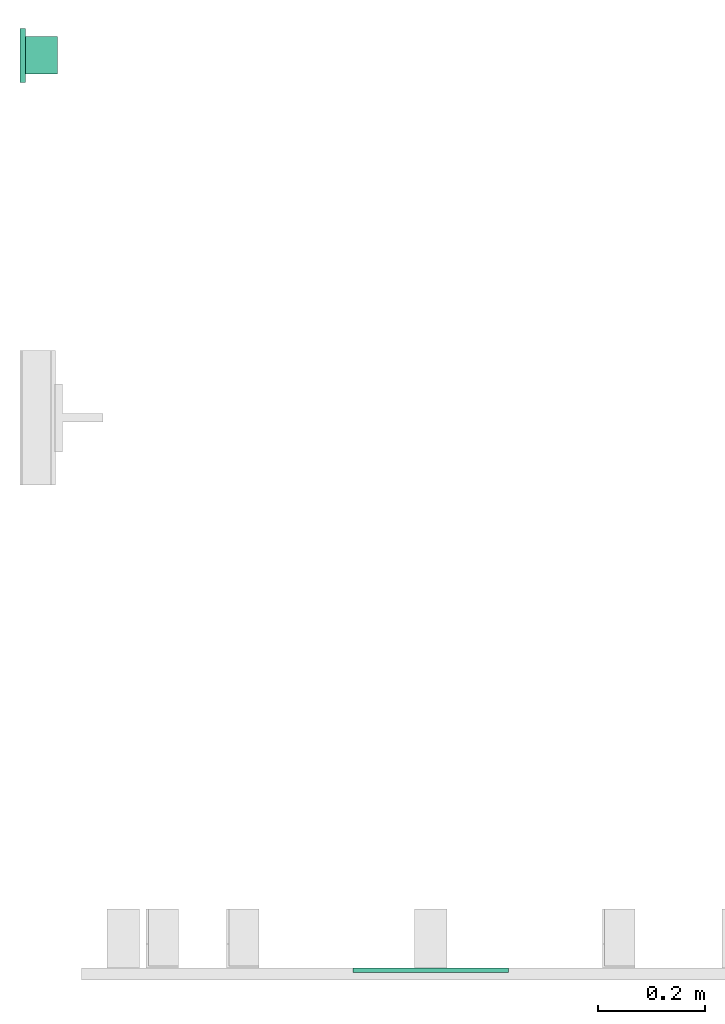
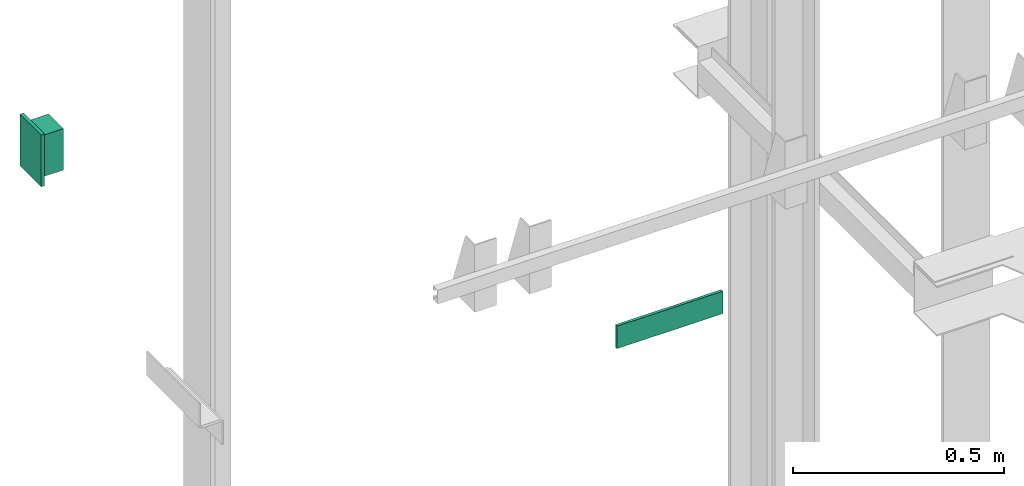
# One storey, part 2 of 3: 1 lamp, 1 switching device.
"""IFC4 building model written with IfcOpenShell, lengths in millimetres."""

from ifc_helpers import new_model, entity, si_unit, converted_unit, frame, origin_with_axes, place, context, subcontext, project, spatial, faceted_brep, element, save


model = new_model("IFC4")

# Units and contexts
context_of_model = context(None, 3, precision=0.01, world=origin_with_axes())
sub_context_1 = subcontext(context_of_model, None, None, "MODEL_VIEW")
sub_context_2 = subcontext(context_of_model, None, None, "MODEL_VIEW")
ifc_project = project(units=[converted_unit("PLANEANGLEUNIT", "degree", entity("IfcPlaneAngleMeasure", 0.017453292519943), si_unit("PLANEANGLEUNIT", "RADIAN"), dimensions=[0, 0, 0, 0, 0, 0, 0]), si_unit("LENGTHUNIT", "METRE", prefix="MILLI"), si_unit("MASSUNIT", "GRAM", prefix="KILO"), converted_unit("TIMEUNIT", "year", entity("IfcTimeMeasure", 31557600.0), si_unit("TIMEUNIT", "SECOND"), dimensions=[0, 0, 1, 0, 0, 0, 0]), si_unit("THERMODYNAMICTEMPERATUREUNIT", "DEGREE_CELSIUS"), si_unit("AREAUNIT", "SQUARE_METRE"), si_unit("FORCEUNIT", "NEWTON"), si_unit("VOLUMEUNIT", "CUBIC_METRE"), si_unit("PRESSUREUNIT", "PASCAL"), si_unit("SOLIDANGLEUNIT", "STERADIAN")], contexts=[context_of_model])

# Site, building, storey
site = spatial("IfcSite", under=ifc_project)
building = spatial("IfcBuilding", under=site, Name="Document")
placement = place(None, origin_with_axes())
storey_placement = place(placement, frame((0.0, 0.0, -4420.0), z_axis=(0.0, 0.0, 1.0), x_axis=(1.0, 0.0, 0.0)))
storey = spatial("IfcBuildingStorey", under=building, at=storey_placement, Name="-1", Elevation=-4420.0)

# Switching device
switching_device_placement = place(storey_placement, frame((765.0, 0.0, 2280.0), z_axis=(0.0, 0.0, 1.0), x_axis=(1.0, 0.0, 0.0)))
element("IfcSwitchingDevice", 1, at=switching_device_placement, inside=storey, context=sub_context_1, shape_type="Brep", body=[
    faceted_brep([(-145.0, -8.0, 32.5), (145.0, -8.0, 32.5), (145.0, 0.0, 32.5), (-145.0, 0.0, 32.5), (-145.0, -8.0, -32.5), (-145.0, 0.0, -32.5), (145.0, 0.0, -32.5), (145.0, -8.0, -32.5)], [[[0, 1, 2, 3]], [[4, 5, 6, 7]], [[0, 3, 5, 4]], [[3, 2, 6, 5]], [[2, 1, 7, 6]], [[1, 0, 4, 7]]]),
])

# Lamp
lamp_placement = place(storey_placement, frame((0.0, 1700.0, 2003.076923076922), z_axis=(0.0, 0.0, 1.0), x_axis=(0.0, -1.0, 0.0)))
element("IfcLamp", 2, at=lamp_placement, inside=storey, ObjectType="Lamp S5500", context=sub_context_2, shape_type="Brep", body=[
    faceted_brep([(50.0, 0.0, 74.99924879807804), (50.0, 10.0, 74.99924879807804), (-50.0, 10.0, 74.99924879807804), (-50.0, 0.0, 74.99924879807804), (50.0, 0.0, -75.00075120192196), (-50.0, 0.0, -75.00075120192196), (-50.0, 10.0, -75.00075120192196), (50.0, 10.0, -75.00075120192196)], [[[0, 1, 2, 3]], [[4, 5, 6, 7]], [[0, 3, 5, 4]], [[3, 2, 6, 5]], [[2, 1, 7, 6]], [[1, 0, 4, 7]]]),
    faceted_brep([(35.0, 10.0, 59.99924879807804), (35.0, 70.0, 59.99924879807804), (-35.0, 70.0, 59.99924879807804), (-35.0, 10.0, 59.99924879807804), (35.0, 10.0, -60.00075120192196), (-35.0, 10.0, -60.00075120192196), (-35.0, 70.0, -60.00075120192196), (35.0, 70.0, -60.00075120192196)], [[[0, 1, 2, 3]], [[4, 5, 6, 7]], [[0, 3, 5, 4]], [[3, 2, 6, 5]], [[2, 1, 7, 6]], [[1, 0, 4, 7]]]),
])

save(model, "model.ifc")
